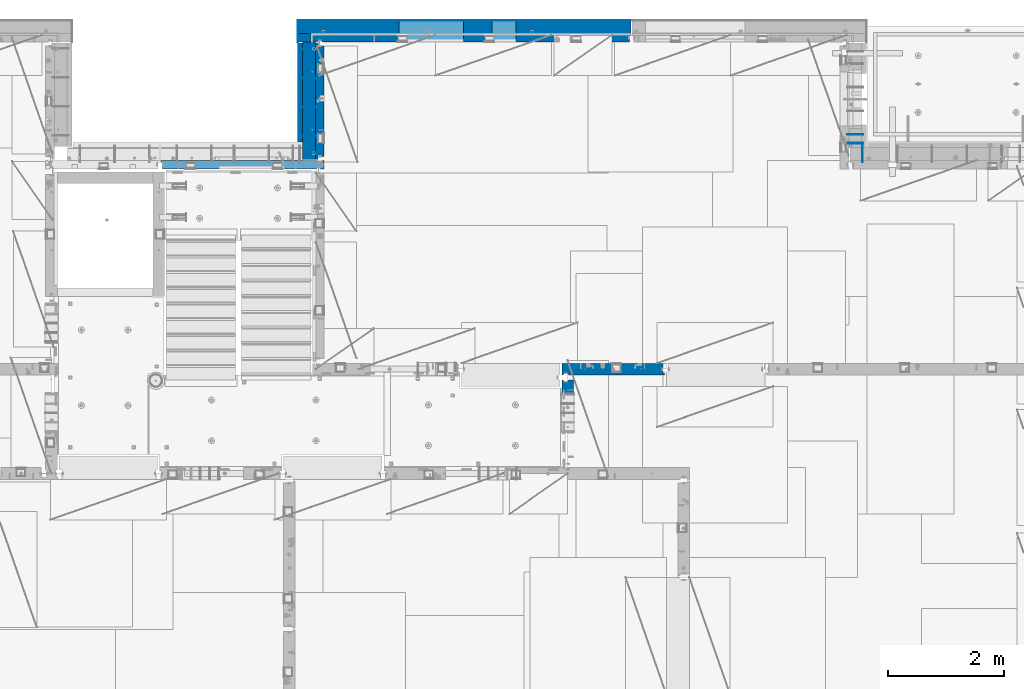
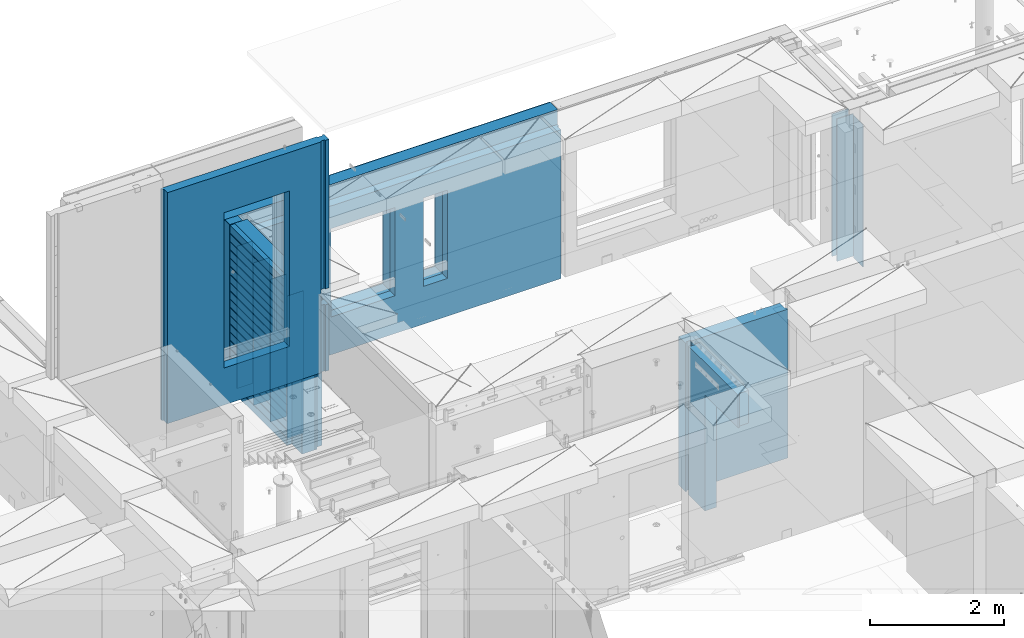
# One storey, part 241 of 352: 18 walls, 7 elements without a shape of their own.
"""IFC2X3 building model written with IfcOpenShell, lengths in millimetres."""

from ifc_helpers import new_model, si_unit, frame, origin_with_axes, place, context, subcontext, project, spatial, faceted_brep, material, type_object, element, aggregate, save


model = new_model("IFC2X3")

# Units and contexts
model_context = context("Model", 3, precision=1e-05, world=origin_with_axes())
body_context = subcontext(model_context, "Body", "Model", "MODEL_VIEW")
ifc_project = project(units=[si_unit("LENGTHUNIT", "METRE", prefix="MILLI"), si_unit("AREAUNIT", "SQUARE_METRE"), si_unit("VOLUMEUNIT", "CUBIC_METRE"), si_unit("MASSUNIT", "GRAM", prefix="KILO"), si_unit("TIMEUNIT", "SECOND"), si_unit("PLANEANGLEUNIT", "RADIAN"), si_unit("SOLIDANGLEUNIT", "STERADIAN"), si_unit("THERMODYNAMICTEMPERATUREUNIT", "DEGREE_CELSIUS"), si_unit("LUMINOUSINTENSITYUNIT", "LUMEN")], contexts=[model_context])

# Site, building, storey
site_placement = place(None, origin_with_axes())
site = spatial("IfcSite", under=ifc_project, at=site_placement, CompositionType="ELEMENT")
building_placement = place(site_placement, origin_with_axes())
building = spatial("IfcBuilding", under=site, at=building_placement, CompositionType="ELEMENT")
storey_placement = place(building_placement, origin_with_axes())
storey = spatial("IfcBuildingStorey", under=building, at=storey_placement, Name="6", CompositionType="ELEMENT", Elevation=0.0)

# Assembly, wall
assembly_1_placement = place(storey_placement, origin_with_axes())
assembly_1 = element("IfcElementAssembly", 1, at=assembly_1_placement, inside=storey, AssemblyPlace="NOTDEFINED", PredefinedType="REINFORCEMENT_UNIT")
ifc_material_1 = material(Name="Undefined")
wall_type_1 = type_object("IfcWallType", PredefinedType="NOTDEFINED")
wall_1_placement = place(assembly_1_placement, frame((31695.0, 20549.9951872276, 98115.0), z_axis=(0.0, 0.0, 1.0), x_axis=(0.0, 1.0, 0.0)))
wall_1 = element("IfcWall", 2, at=wall_1_placement, type_object=wall_type_1, material=ifc_material_1, Name="(PD)", context=body_context, shape_type="Brep", body=[
    faceted_brep([(0.0, 5.0, -1300.0), (0.0, 5.0, 1300.0), (280.0, 5.0, 1300.0), (280.0, 5.0, -1300.0), (0.0, -5.0, 1300.0), (280.0, -5.0, 1300.0), (0.0, -5.0, -1300.0), (280.0, -5.0, -1300.0)], [[[0, 1, 2, 3]], [[1, 4, 5, 2]], [[4, 6, 7, 5]], [[6, 0, 3, 7]], [[5, 7, 3, 2]], [[6, 4, 1, 0]]]),
])
aggregate(assembly_1, [wall_1])

# Assembly, walls
assembly_2_placement = place(storey_placement, origin_with_axes())
assembly_2 = element("IfcElementAssembly", 3, at=assembly_2_placement, inside=storey, AssemblyPlace="NOTDEFINED", PredefinedType="REINFORCEMENT_UNIT")
wall_2_placement = place(assembly_2_placement, frame((22290.0, 22495.0, 98110.0), z_axis=(0.0, 0.0, 1.0), x_axis=(-1.0, 3.00000001838171e-08, 0.0)))
wall_2 = element("IfcWall", 4, at=wall_2_placement, type_object=wall_type_1, material=ifc_material_1, Name="(PD)", context=body_context, shape_type="Brep", body=[
    faceted_brep([(0.0, 5.0, -1300.0), (0.0, 5.0, 1300.0), (280.0, 5.0, 1300.0), (280.0, 5.0, -1300.0), (0.0, -5.0, 1300.0), (280.0, -5.0, 1300.0), (0.0, -5.0, -1300.0), (280.0, -5.0, -1300.0)], [[[0, 1, 2, 3]], [[1, 4, 5, 2]], [[4, 6, 7, 5]], [[6, 0, 3, 7]], [[5, 7, 3, 2]], [[6, 4, 1, 0]]]),
])
wall_3_placement = place(assembly_2_placement, frame((22290.0, 21995.0, 98110.0), z_axis=(0.0, 0.0, 1.0), x_axis=(-1.0, 3.00000001838171e-08, 0.0)))
wall_3 = element("IfcWall", 5, at=wall_3_placement, type_object=wall_type_1, material=ifc_material_1, Name="(PD)", context=body_context, shape_type="Brep", body=[
    faceted_brep([(0.0, 5.0, -1300.0), (0.0, 5.0, 1300.0), (280.0, 5.0, 1300.0), (280.0, 5.0, -1300.0), (0.0, -5.0, 1300.0), (280.0, -5.0, 1300.0), (0.0, -5.0, -1300.0), (280.0, -5.0, -1300.0)], [[[0, 1, 2, 3]], [[1, 4, 5, 2]], [[4, 6, 7, 5]], [[6, 0, 3, 7]], [[5, 7, 3, 2]], [[6, 4, 1, 0]]]),
])
wall_4_placement = place(assembly_2_placement, frame((22290.0, 21495.0, 98110.0), z_axis=(0.0, 0.0, 1.0), x_axis=(-1.0, 3.00000001838171e-08, 0.0)))
wall_4 = element("IfcWall", 6, at=wall_4_placement, type_object=wall_type_1, material=ifc_material_1, Name="(PD)", context=body_context, shape_type="Brep", body=[
    faceted_brep([(0.0, 5.0, -1300.0), (0.0, 5.0, 1300.0), (280.0, 5.0, 1300.0), (280.0, 5.0, -1300.0), (0.0, -5.0, 1300.0), (280.0, -5.0, 1300.0), (0.0, -5.0, -1300.0), (280.0, -5.0, -1300.0)], [[[0, 1, 2, 3]], [[1, 4, 5, 2]], [[4, 6, 7, 5]], [[6, 0, 3, 7]], [[5, 7, 3, 2]], [[6, 4, 1, 0]]]),
])

assembly_3_placement = place(storey_placement, origin_with_axes())
assembly_3 = element("IfcElementAssembly", 7, at=assembly_3_placement, inside=storey, AssemblyPlace="NOTDEFINED", PredefinedType="REINFORCEMENT_UNIT")
wall_5_placement = place(assembly_3_placement, frame((31429.9951872276, 20875.0, 98115.0), z_axis=(0.0, 0.0, 1.0), x_axis=(1.0, 0.0, 0.0)))
wall_5 = element("IfcWall", 8, at=wall_5_placement, type_object=wall_type_1, material=ifc_material_1, Name="(PD)", context=body_context, shape_type="Brep", body=[
    faceted_brep([(0.0, 5.0, -1300.0), (0.0, 5.0, 1300.0), (280.0, 5.0, 1300.0), (280.0, 5.0, -1300.0), (0.0, -5.0, 1300.0), (280.0, -5.0, 1300.0), (0.0, -5.0, -1300.0), (280.0, -5.0, -1300.0)], [[[0, 1, 2, 3]], [[1, 4, 5, 2]], [[4, 6, 7, 5]], [[6, 0, 3, 7]], [[5, 7, 3, 2]], [[6, 4, 1, 0]]]),
])
wall_6_placement = place(assembly_3_placement, frame((31429.9951872276, 21025.0, 98115.0), z_axis=(0.0, 0.0, 1.0), x_axis=(1.0, 0.0, 0.0)))
wall_6 = element("IfcWall", 9, at=wall_6_placement, type_object=wall_type_1, material=ifc_material_1, Name="(PD)", context=body_context, shape_type="Brep", body=[
    faceted_brep([(0.0, 5.0, -1300.0), (0.0, 5.0, 1300.0), (280.0, 5.0, 1300.0), (280.0, 5.0, -1300.0), (0.0, -5.0, 1300.0), (280.0, -5.0, 1300.0), (0.0, -5.0, -1300.0), (280.0, -5.0, -1300.0)], [[[0, 1, 2, 3]], [[1, 4, 5, 2]], [[4, 6, 7, 5]], [[6, 0, 3, 7]], [[5, 7, 3, 2]], [[6, 4, 1, 0]]]),
])
aggregate(assembly_3, [wall_5, wall_6])

# Wall
wall_7_placement = place(assembly_2_placement, frame((22290.0, 20995.0, 98110.0), z_axis=(0.0, 0.0, 1.0), x_axis=(-1.0, 3.00000001838171e-08, 0.0)))
wall_7 = element("IfcWall", 10, at=wall_7_placement, type_object=wall_type_1, material=ifc_material_1, Name="(PD)", context=body_context, shape_type="Brep", body=[
    faceted_brep([(0.0, 5.0, -1300.0), (0.0, 5.0, 1300.0), (280.0, 5.0, 1300.0), (280.0, 5.0, -1300.0), (0.0, -5.0, 1300.0), (280.0, -5.0, 1300.0), (0.0, -5.0, -1300.0), (280.0, -5.0, -1300.0)], [[[0, 1, 2, 3]], [[1, 4, 5, 2]], [[4, 6, 7, 5]], [[6, 0, 3, 7]], [[5, 7, 3, 2]], [[6, 4, 1, 0]]]),
])

# Assembly, wall
assembly_4_placement = place(storey_placement, origin_with_axes())
assembly_4 = element("IfcElementAssembly", 11, at=assembly_4_placement, inside=storey, AssemblyPlace="NOTDEFINED", PredefinedType="REINFORCEMENT_UNIT")
ifc_material_2 = material(Name="CONCRETE/C25/30")
wall_type_2 = type_object("IfcWallType", PredefinedType="NOTDEFINED")
wall_8_placement = place(assembly_4_placement, frame((26510.0014364077, 16980.0, 98112.5), z_axis=(0.0, 0.0, 1.0), x_axis=(1.0, 0.0, 0.0)))
wall_8 = element("IfcWall", 12, at=wall_8_placement, type_object=wall_type_2, material=ifc_material_2, context=body_context, shape_type="Brep", body=[
    faceted_brep([(1739.99847412109, 100.0, 1357.5), (1739.99847412109, -57.0, 1357.5), (1739.99847412109, -57.0, -1357.5), (1739.99847412109, 100.0, -1357.5), (1769.99847412109, -70.0, 1357.5), (1769.99847412109, -70.0, -1357.5), (0.0, -100.0, -1357.5), (0.0, -100.0, 1357.5), (0.0, 100.0, 1357.5), (0.0, 100.0, -1357.5), (29.998563592264, -100.0, -1357.5), (29.998563592264, -100.0, 1357.5), (29.998563592264, -80.0008544921875, -1357.5), (29.998563592264, -80.0008544921875, 1357.5), (109.998563592264, -80.0008544921875, -1357.5), (109.998563592264, -80.0008544921875, 1357.5), (109.998563592264, -100.0, -1357.5), (109.998563592264, -100.0, 1357.5), (1769.99847412109, -100.0, -1357.5), (1769.99847412109, -100.0, 1357.5)], [[[0, 1, 2, 3]], [[4, 5, 2, 1]], [[6, 7, 8, 9]], [[7, 6, 10, 11]], [[11, 10, 12, 13]], [[13, 12, 14, 15]], [[15, 14, 16, 17]], [[18, 19, 17, 16]], [[0, 8, 7, 11, 13, 15, 17, 19, 4, 1]], [[9, 8, 0, 3]], [[18, 16, 14, 12, 10, 6, 9, 3, 2, 5]], [[19, 18, 5, 4]]]),
])
aggregate(assembly_4, [wall_8])

assembly_5_placement = place(storey_placement, origin_with_axes())
assembly_5 = element("IfcElementAssembly", 13, at=assembly_5_placement, inside=storey, AssemblyPlace="NOTDEFINED", PredefinedType="REINFORCEMENT_UNIT")
wall_9_placement = place(assembly_5_placement, frame((26609.9991475894, 15280.0004107749, 98112.5), z_axis=(0.0, 0.0, 1.0), x_axis=(0.0, 1.0, 0.0)))
wall_9 = element("IfcWall", 14, at=wall_9_placement, type_object=wall_type_2, material=ifc_material_2, context=body_context, shape_type="Brep", body=[
    faceted_brep([(1509.99949975397, 70.0, 1357.5), (1489.99949975397, 70.0, 1357.5), (1489.99949975397, 70.0, -1357.5), (1509.99949975397, 70.0, -1357.5), (1489.99949975397, -10.0, 1357.5), (1489.99949975397, -10.0, -1357.5), (1509.99949975397, -10.0, 1357.5), (1509.99949975397, -10.0, -1357.5), (29.9995892251427, 70.0, 1357.5), (29.9995892251427, 70.0, 762.5), (59.9995892251427, 57.0, 762.5), (59.9995892251427, 57.0, 1357.5), (29.9995892251427, 100.0, 1357.5), (29.9995892251427, 100.0, 762.5), (1509.99949975397, 100.0, 1357.5), (1509.99949975397, 100.0, -1357.5), (1019.99979369292, 100.0, -1357.5), (1019.99979369292, 100.0, 762.5), (1019.99979369292, -100.0, 762.5), (1019.99979369292, -100.0, -1357.5), (59.9995892251427, -100.0, 762.5), (59.9995892251427, -100.0, 1357.5), (1509.99949975397, -100.0, -1357.5), (1509.99949975397, -100.0, 1357.5)], [[[0, 1, 2, 3]], [[4, 5, 2, 1]], [[6, 7, 5, 4]], [[8, 9, 10, 11]], [[12, 13, 9, 8]], [[12, 14, 15, 16, 17, 13]], [[18, 17, 16, 19]], [[9, 13, 17, 18, 20, 10]], [[21, 11, 10, 20]], [[18, 19, 22, 23, 21, 20]], [[1, 0, 14, 12, 8, 11, 21, 23, 6, 4]], [[15, 14, 0, 3]], [[22, 19, 16, 15, 3, 2, 5, 7]], [[23, 22, 7, 6]]]),
])
aggregate(assembly_5, [wall_9])

# Wall
ifc_material_3 = material(Name="COS5gt")
wall_type_3 = type_object("IfcWallType", PredefinedType="NOTDEFINED")
wall_10_placement = place(assembly_2_placement, frame((22150.0, 20595.0, 98247.5), z_axis=(0.0, 0.0, 1.0), x_axis=(0.0, 1.0, 0.0)))
wall_10 = element("IfcWall", 15, at=wall_10_placement, type_object=wall_type_3, material=ifc_material_3, context=body_context, shape_type="Brep", body=[
    faceted_brep([(0.0, 110.0, -1492.5), (0.0, 110.0, 1492.5), (2025.0, 110.0, 1492.5), (2025.0, 110.0, -1492.5), (0.0, -110.0, 1492.5), (2025.0, -110.0, 1492.5), (0.0, -110.0, -1492.5), (2025.0, -110.0, -1492.5)], [[[0, 1, 2, 3]], [[1, 4, 5, 2]], [[4, 6, 7, 5]], [[6, 0, 3, 7]], [[5, 7, 3, 2]], [[6, 4, 1, 0]]]),
])

# Assembly, walls
assembly_6_placement = place(storey_placement, origin_with_axes())
assembly_6 = element("IfcElementAssembly", 16, at=assembly_6_placement, inside=storey, AssemblyPlace="NOTDEFINED", PredefinedType="REINFORCEMENT_UNIT")
ifc_material_4 = material()
wall_11_placement = place(assembly_6_placement, frame((22075.0, 22620.0, 98247.5), z_axis=(0.0, 0.0, 1.0), x_axis=(0.0, 1.0, 0.0)))
wall_11 = element("IfcWall", 17, at=wall_11_placement, type_object=wall_type_3, material=ifc_material_4, context=body_context, shape_type="Brep", body=[
    faceted_brep([(0.0, 110.0, -1492.5), (0.0, 110.0, 1492.5), (150.0, 110.0, 1492.5), (150.0, 110.0, -1492.5), (0.0, -110.0, 1492.5), (150.0, -110.0, 1492.5), (0.0, -110.0, -1492.5), (150.0, -110.0, -1492.5)], [[[0, 1, 2, 3]], [[1, 4, 5, 2]], [[4, 6, 7, 5]], [[6, 0, 3, 7]], [[5, 7, 3, 2]], [[6, 4, 1, 0]]]),
])
wall_12_placement = place(assembly_6_placement, frame((22260.0, 22880.0, 98247.5), z_axis=(0.0, 0.0, 1.0), x_axis=(1.0, 0.0, 0.0)))
wall_12 = element("IfcWall", 18, at=wall_12_placement, type_object=wall_type_3, material=ifc_material_4, context=body_context, shape_type="Brep", body=[
    faceted_brep([(-295.0, 110.0, 1492.5), (-295.0, -110.0, 1492.5), (5445.0, -110.0, 1492.5), (5445.0, 110.0, 1492.5), (-295.0, -110.0, -1492.5), (-295.0, 110.0, -1492.5), (5445.0, 110.0, -1492.5), (5445.0, -110.0, -1492.5), (3044.99635379813, 110.0, -802.5), (3454.99635379813, 110.0, -802.5), (3454.99635379813, 110.0, 807.5), (3044.99635379813, 110.0, 807.5), (1444.99910133321, 110.0, -802.5), (2554.99910133321, 110.0, -802.5), (2554.99910133321, 110.0, 807.5), (1444.99910133321, 110.0, 807.5), (1444.99910133321, -110.0, -802.5), (2554.99910133321, -110.0, -802.5), (1444.99910133321, -110.0, 807.5), (2554.99910133321, -110.0, 807.5), (3044.99635379813, -110.0, -802.5), (3044.99635379813, -110.0, 807.5), (3454.99635379813, -110.0, 807.5), (3454.99635379813, -110.0, -802.5)], [[[0, 1, 2, 3]], [[4, 1, 0, 5]], [[4, 5, 6, 7]], [[2, 7, 6, 3]], [[5, 0, 3, 6], [8, 9, 10, 11], [12, 13, 14, 15]], [[12, 16, 17, 13]], [[15, 18, 16, 12]], [[14, 19, 18, 15]], [[13, 17, 19, 14]], [[1, 4, 7, 2], [20, 21, 22, 23], [16, 18, 19, 17]], [[10, 22, 21, 11]], [[9, 23, 22, 10]], [[8, 20, 23, 9]], [[11, 21, 20, 8]]]),
])

# Wall
ifc_material_5 = material(Name="CONCRETE/C30/37")
wall_type_4 = type_object("IfcWallType", PredefinedType="NOTDEFINED")
wall_13_placement = place(assembly_2_placement, frame((21997.5, 20900.0, 98247.5), z_axis=(0.0, 0.0, 1.0), x_axis=(0.0, 1.0, 0.0)))
wall_13 = element("IfcWall", 19, at=wall_13_placement, type_object=wall_type_4, material=ifc_material_5, context=body_context, shape_type="Brep", body=[
    faceted_brep([(1705.0, 42.5, -1357.0), (0.0, 42.5, -1357.00000005524), (0.0, 32.4999992507037, -1355.00000000074), (1705.0, 32.5, -1355.0), (1705.0, 32.5, -1345.0), (0.0, 32.4999991127006, -1344.99999959956), (0.0, 42.5, -1343.00000011075), (1705.0, 42.5, -1343.0), (0.0, -42.5, -1492.5), (0.0, 42.5, -1492.5), (1705.0, 42.5, -1492.5), (1705.0, -42.5, -1492.5), (0.0, -42.5, 1492.5), (1705.0, -42.5, 1492.5), (0.0, 42.5, 1492.5), (1705.0, 42.5, 1492.5), (1705.0, 42.5, 1357.0), (0.0, 42.5, 1356.99999988925), (1705.0, 32.5, 1355.0), (-3.63797880709171e-12, 32.4999991127006, 1355.00000040044), (1705.0, 32.5, 1345.0), (-3.63797880709171e-12, 32.4999992507037, 1344.99999999926), (1705.0, 42.5, 1343.0), (0.0, 42.5, 1342.99999994476), (1705.0, 42.5, 1207.0), (0.0, 42.5, 1206.99999988925), (1705.0, 32.5, 1205.0), (0.0, 32.4999991127006, 1205.00000040044), (1705.0, 32.5, 1195.0), (0.0, 32.4999992507037, 1194.99999999926), (1705.0, 42.5, 1193.0), (0.0, 42.5, 1192.99999994476), (1705.0, 42.5, 1057.0), (0.0, 42.5, 1056.99999988925), (1705.0, 32.5, 1055.0), (0.0, 32.4999991127006, 1055.00000040044), (1705.0, 32.5, 1045.0), (0.0, 32.4999992507037, 1044.99999999926), (1705.0, 42.5, 1043.0), (0.0, 42.5, 1042.99999994476), (1705.0, 42.5, 907.0), (0.0, 42.5, 906.999999889245), (1705.0, 32.5, 905.0), (0.0, 32.4999991127006, 905.00000040044), (1705.0, 32.5, 895.0), (0.0, 32.4999992507037, 894.999999999258), (1705.0, 42.5, 893.0), (0.0, 42.5, 892.999999944761), (1705.0, 42.5, 757.0), (0.0, 42.5, 756.999999889245), (1705.0, 32.5, 755.0), (0.0, 32.4999991127006, 755.00000040044), (1705.0, 32.5, 745.0), (0.0, 32.4999992507037, 744.999999999258), (1705.0, 42.5, 743.0), (0.0, 42.5, 742.999999944761), (1705.0, 42.5, 607.0), (0.0, 42.5, 606.999999889245), (1705.0, 32.5, 605.0), (3.63797880709171e-12, 32.4999991127006, 605.00000040044), (1705.0, 32.5, 595.0), (3.63797880709171e-12, 32.4999992507037, 594.999999999258), (1705.0, 42.5, 593.0), (0.0, 42.5, 592.999999944761), (1705.0, 42.5, 457.0), (0.0, 42.5, 456.999999889245), (1705.0, 32.5, 455.0), (0.0, 32.4999991127006, 455.00000040044), (1705.0, 32.5, 445.0), (0.0, 32.4999992507037, 444.999999999258), (1705.0, 42.5, 443.0), (0.0, 42.5, 442.999999944761), (1705.0, 42.5, 307.0), (0.0, 42.5, 306.999999889245), (1705.0, 32.5, 305.0), (-3.63797880709171e-12, 32.4999991127006, 305.00000040044), (1705.0, 32.5, 295.0), (-3.63797880709171e-12, 32.4999992507037, 294.999999999258), (1705.0, 42.5, 293.0), (0.0, 42.5, 292.999999944761), (1705.0, 42.5, 157.0), (0.0, 42.5, 156.999999889245), (1705.0, 32.5, 155.0), (-3.63797880709171e-12, 32.4999991127006, 155.00000040044), (1705.0, 32.5, 145.0), (-3.63797880709171e-12, 32.4999992507037, 144.999999999258), (1705.0, 42.5, 143.0), (0.0, 42.5, 142.999999944761), (1705.0, 42.5, 7.0), (0.0, 42.5, 6.99999988924537), (1705.0, 32.5, 5.0), (0.0, 32.4999991127006, 5.0000004004396), (1705.0, 32.5, -5.0), (0.0, 32.4999992507037, -5.00000000074215), (1705.0, 42.5, -7.0), (0.0, 42.5, -7.00000005523907), (1705.0, 42.5, -143.0), (0.0, 42.5, -143.000000110755), (1705.0, 32.5, -145.0), (3.63797880709171e-12, 32.4999991127006, -144.99999959956), (1705.0, 32.5, -155.0), (3.63797880709171e-12, 32.4999992507037, -155.000000000742), (1705.0, 42.5, -157.0), (0.0, 42.5, -157.000000055239), (1705.0, 42.5, -293.0), (0.0, 42.5, -293.000000110755), (1705.0, 32.5, -295.0), (0.0, 32.4999991127006, -294.99999959956), (1705.0, 32.5, -305.0), (0.0, 32.4999992507037, -305.000000000742), (1705.0, 42.5, -307.0), (0.0, 42.5, -307.000000055239), (1705.0, 42.5, -443.0), (0.0, 42.5, -443.000000110755), (1705.0, 32.5, -445.0), (0.0, 32.4999991127006, -444.99999959956), (1705.0, 32.5, -455.0), (0.0, 32.4999992507037, -455.000000000742), (1705.0, 42.5, -457.0), (0.0, 42.5, -457.000000055239), (1705.0, 42.5, -593.0), (0.0, 42.5, -593.000000110755), (1705.0, 32.5, -595.0), (3.63797880709171e-12, 32.4999991127006, -594.99999959956), (1705.0, 32.5, -605.0), (3.63797880709171e-12, 32.4999992507037, -605.000000000742), (1705.0, 42.5, -607.0), (0.0, 42.5, -607.000000055239), (1705.0, 42.5, -743.0), (0.0, 42.5, -743.000000110755), (1705.0, 32.5, -745.0), (0.0, 32.4999991127006, -744.99999959956), (1705.0, 32.5, -755.0), (0.0, 32.4999992507037, -755.000000000742), (1705.0, 42.5, -757.0), (0.0, 42.5, -757.000000055239), (1705.0, 42.5, -893.0), (0.0, 42.5, -893.000000110755), (1705.0, 32.5, -895.0), (0.0, 32.4999991127006, -894.99999959956), (1705.0, 32.5, -905.0), (0.0, 32.4999992507037, -905.000000000742), (1705.0, 42.5, -907.0), (0.0, 42.5, -907.000000055239), (1705.0, 42.5, -1043.0), (0.0, 42.5, -1043.00000011075), (1705.0, 32.5, -1045.0), (0.0, 32.4999991127006, -1044.99999959956), (1705.0, 32.5, -1055.0), (0.0, 32.4999992507037, -1055.00000000074), (1705.0, 42.5, -1057.0), (0.0, 42.5, -1057.00000005524), (1705.0, 42.5, -1193.0), (0.0, 42.5, -1193.00000011075), (1705.0, 32.5, -1195.0), (0.0, 32.4999991127006, -1194.99999959956), (1705.0, 32.5, -1205.0), (0.0, 32.4999992507037, -1205.00000000074), (1705.0, 42.5, -1207.0), (0.0, 42.5, -1207.00000005524)], [[[0, 1, 2, 3]], [[4, 5, 6, 7]], [[3, 2, 5, 4]], [[8, 9, 10, 11]], [[12, 8, 11, 13]], [[14, 12, 13, 15]], [[14, 15, 16, 17]], [[18, 19, 17, 16]], [[20, 21, 19, 18]], [[22, 23, 21, 20]], [[24, 25, 23, 22]], [[26, 27, 25, 24]], [[28, 29, 27, 26]], [[30, 31, 29, 28]], [[32, 33, 31, 30]], [[34, 35, 33, 32]], [[36, 37, 35, 34]], [[38, 39, 37, 36]], [[40, 41, 39, 38]], [[42, 43, 41, 40]], [[44, 45, 43, 42]], [[46, 47, 45, 44]], [[48, 49, 47, 46]], [[50, 51, 49, 48]], [[52, 53, 51, 50]], [[54, 55, 53, 52]], [[56, 57, 55, 54]], [[58, 59, 57, 56]], [[60, 61, 59, 58]], [[62, 63, 61, 60]], [[64, 65, 63, 62]], [[66, 67, 65, 64]], [[68, 69, 67, 66]], [[70, 71, 69, 68]], [[72, 73, 71, 70]], [[74, 75, 73, 72]], [[76, 77, 75, 74]], [[78, 79, 77, 76]], [[80, 81, 79, 78]], [[82, 83, 81, 80]], [[84, 85, 83, 82]], [[86, 87, 85, 84]], [[88, 89, 87, 86]], [[90, 91, 89, 88]], [[92, 93, 91, 90]], [[94, 95, 93, 92]], [[96, 97, 95, 94]], [[98, 99, 97, 96]], [[100, 101, 99, 98]], [[102, 103, 101, 100]], [[104, 105, 103, 102]], [[106, 107, 105, 104]], [[108, 109, 107, 106]], [[110, 111, 109, 108]], [[112, 113, 111, 110]], [[114, 115, 113, 112]], [[116, 117, 115, 114]], [[118, 119, 117, 116]], [[120, 121, 119, 118]], [[122, 123, 121, 120]], [[124, 125, 123, 122]], [[126, 127, 125, 124]], [[128, 129, 127, 126]], [[130, 131, 129, 128]], [[132, 133, 131, 130]], [[134, 135, 133, 132]], [[136, 137, 135, 134]], [[138, 139, 137, 136]], [[140, 141, 139, 138]], [[142, 143, 141, 140]], [[144, 145, 143, 142]], [[146, 147, 145, 144]], [[148, 149, 147, 146]], [[150, 151, 149, 148]], [[152, 153, 151, 150]], [[154, 155, 153, 152]], [[156, 157, 155, 154]], [[158, 159, 157, 156]], [[7, 6, 159, 158]], [[21, 23, 25, 27, 29, 31, 33, 35, 37, 39, 41, 43, 45, 47, 49, 51, 53, 55, 57, 59, 61, 63, 65, 67, 69, 71, 73, 75, 77, 79, 81, 83, 85, 87, 89, 91, 93, 95, 97, 99, 101, 103, 105, 107, 109, 111, 113, 115, 117, 119, 121, 123, 125, 127, 129, 131, 133, 135, 137, 139, 141, 143, 145, 147, 149, 151, 153, 155, 157, 159, 6, 5, 2, 1, 9, 8, 12, 14, 17, 19]], [[10, 9, 1, 0]], [[15, 13, 11, 10, 0, 3, 4, 7, 158, 156, 154, 152, 150, 148, 146, 144, 142, 140, 138, 136, 134, 132, 130, 128, 126, 124, 122, 120, 118, 116, 114, 112, 110, 108, 106, 104, 102, 100, 98, 96, 94, 92, 90, 88, 86, 84, 82, 80, 78, 76, 74, 72, 70, 68, 66, 64, 62, 60, 58, 56, 54, 52, 50, 48, 46, 44, 42, 40, 38, 36, 34, 32, 30, 28, 26, 24, 22, 20, 18, 16]]]),
])

wall_type_5 = type_object("IfcWallType", PredefinedType="NOTDEFINED")
wall_14_placement = place(assembly_6_placement, frame((22192.5, 22695.0, 98112.5), z_axis=(0.0, 0.0, 1.0), x_axis=(1.0, 0.0, 0.0)))
wall_14 = element("IfcWall", 20, at=wall_14_placement, type_object=wall_type_5, material=ifc_material_2, context=body_context, shape_type="Brep", body=[
    faceted_brep([(3112.49635379813, 75.0, 942.5), (3112.49635379813, -75.0000009061441, 942.5), (3112.49635379813, -75.0000002303786, -667.5), (3112.49635379813, 75.0, -667.5), (3522.49635379813, -75.0000001420558, -667.5), (3522.49635379813, 75.0, -667.5), (3522.49635379813, -75.0000008178213, 942.5), (3522.49635379813, 75.0, 942.5), (5482.5, -75.0, 1357.5), (5482.5, -75.0, -1357.5), (5482.5, 24.9999980926514, -1357.5), (5482.5, 24.9999980926514, 1357.5), (5512.5, 45.0, 1357.5), (5512.5, 75.0, 1357.5), (0.0, 75.0, 1357.5), (0.0, -75.0, 1357.5), (92.5, -75.0, 1357.5), (102.5, -55.0000022791319, 1357.5), (182.5, -55.0000022791319, 1357.5), (192.5, -75.0000022791319, 1357.5), (0.0, -75.0, -1357.5), (0.0, 75.0, -1357.5), (92.5, -75.0, -1357.5), (102.5, -55.0000022791319, -1357.5), (182.5, -55.0000022791319, -1357.5), (192.5, -75.0, -1357.5), (5512.5, 75.0, -1357.5), (5512.5, 45.0, -1357.5), (1512.49910133321, 75.0, -667.5), (2622.49910133321, 75.0, -667.5), (2622.49910133321, 75.0, 942.5), (1512.49910133321, 75.0, 942.5), (1512.49910133321, -75.000000575048, -667.5), (2622.49910133321, -75.000000335931, -667.5), (1512.49910133321, -75.0000012508135, 942.5), (2622.49910133321, -75.0000010116964, 942.5)], [[[0, 1, 2, 3]], [[3, 2, 4, 5]], [[5, 4, 6, 7]], [[7, 6, 1, 0]], [[8, 9, 10, 11]], [[8, 11, 12, 13, 14, 15, 16, 17, 18, 19]], [[20, 15, 14, 21]], [[15, 20, 22, 16]], [[16, 22, 23, 17]], [[17, 23, 24, 18]], [[19, 18, 24, 25]], [[23, 22, 20, 21, 26, 27, 10, 9, 25, 24]], [[12, 11, 10, 27]], [[26, 13, 12, 27]], [[21, 14, 13, 26], [3, 5, 7, 0], [28, 29, 30, 31]], [[28, 32, 33, 29]], [[31, 34, 32, 28]], [[30, 35, 34, 31]], [[29, 33, 35, 30]], [[9, 8, 19, 25], [2, 1, 6, 4], [32, 34, 35, 33]]]),
])

wall_15_placement = place(assembly_2_placement, frame((22335.0, 20595.0, 98112.5), z_axis=(0.0, 0.0, 1.0), x_axis=(0.0, 1.0, 0.0)))
wall_15 = element("IfcWall", 21, at=wall_15_placement, type_object=wall_type_5, material=ifc_material_2, context=body_context, shape_type="Brep", body=[
    faceted_brep([(0.0, 40.0, 1357.5), (0.0, 40.0, -1357.5), (50.0, 27.0, -1357.5), (50.0, 27.0, 1357.5), (50.0, -75.0, 1357.5), (50.0, -75.0, -1357.5), (0.0, 75.0, -1357.5), (0.0, 75.0, 1357.5), (2009.99999772087, 75.0, 1357.5), (2009.99999772087, 75.0, -1357.5), (2009.99999772087, 40.0, 1357.5), (2009.99999772087, 40.0, -1357.5), (1959.99999772087, 27.0, 1357.5), (1959.99999772087, 27.0, -1357.5), (1959.99999772087, -75.0, 1357.5), (1959.99999772087, -75.0, -1357.5)], [[[0, 1, 2, 3]], [[4, 3, 2, 5]], [[6, 7, 8, 9]], [[9, 8, 10, 11]], [[12, 13, 11, 10]], [[14, 15, 13, 12]], [[15, 14, 4, 5]], [[1, 6, 9, 11, 13, 15, 5, 2]], [[7, 6, 1, 0]], [[14, 12, 10, 8, 7, 0, 3, 4]]]),
])

aggregate(assembly_2, [wall_10, wall_2, wall_3, wall_4, wall_7, wall_13, wall_15])

wall_type_6 = type_object("IfcWallType", PredefinedType="NOTDEFINED")
wall_16_placement = place(assembly_6_placement, frame((21960.0001313636, 22620.0, 98247.5), z_axis=(0.0, 0.0, 1.0), x_axis=(0.0, 1.0, 0.0)))
wall_16 = element("IfcWall", 22, at=wall_16_placement, type_object=wall_type_6, material=ifc_material_5, context=body_context, shape_type="Brep", body=[
    faceted_brep([(0.0, 5.0, -1492.5), (0.0, 5.0, 1492.5), (370.0, 5.0, 1492.5), (370.0, 5.0, -1492.5), (0.0, -5.0, 1492.5), (370.0, -5.0, 1492.5), (0.0, -5.0, -1492.5), (370.0, -5.0, -1492.5)], [[[0, 1, 2, 3]], [[1, 4, 5, 2]], [[4, 6, 7, 5]], [[6, 0, 3, 7]], [[5, 7, 3, 2]], [[6, 4, 1, 0]]]),
])

wall_17_placement = place(assembly_6_placement, frame((22260.0, 22995.0, 98247.5), z_axis=(0.0, 0.0, 1.0), x_axis=(1.0, 0.0, 0.0)))
wall_17 = element("IfcWall", 23, at=wall_17_placement, type_object=wall_type_6, material=ifc_material_5, context=body_context, shape_type="Brep", body=[
    faceted_brep([(-305.0, 5.0, 1492.5), (-305.0, -5.0, 1492.5), (5445.0, -5.0, 1492.5), (5445.0, 5.0, 1492.5), (-305.0, -5.0, -1492.5), (-305.0, 5.0, -1492.5), (5445.0, 5.0, -1492.5), (5445.0, -5.0, -1492.5), (3044.99635379813, 5.0, -802.5), (3454.99635379813, 5.0, -802.5), (3454.99635379813, 5.0, 807.5), (3044.99635379813, 5.0, 807.5), (1444.99910133321, 5.0, -802.5), (2554.99910133321, 5.0, -802.5), (2554.99910133321, 5.0, 807.5), (1444.99910133321, 5.0, 807.5), (1444.99910133321, -5.0, -802.5), (2554.99910133321, -5.0, -802.5), (1444.99910133321, -5.0, 807.5), (2554.99910133321, -5.0, 807.5), (3044.99635379813, -5.0, -802.5), (3044.99635379813, -5.0, 807.5), (3454.99635379813, -5.0, 807.5), (3454.99635379813, -5.0, -802.5)], [[[0, 1, 2, 3]], [[4, 1, 0, 5]], [[4, 5, 6, 7]], [[2, 7, 6, 3]], [[5, 0, 3, 6], [8, 9, 10, 11], [12, 13, 14, 15]], [[12, 16, 17, 13]], [[15, 18, 16, 12]], [[14, 19, 18, 15]], [[13, 17, 19, 14]], [[1, 4, 7, 2], [20, 21, 22, 23], [16, 18, 19, 17]], [[10, 22, 21, 11]], [[9, 23, 22, 10]], [[8, 20, 23, 9]], [[11, 21, 20, 8]]]),
])

aggregate(assembly_6, [wall_16, wall_11, wall_12, wall_17, wall_14])

# Assembly, wall
assembly_7_placement = place(storey_placement, origin_with_axes())
assembly_7 = element("IfcElementAssembly", 24, at=assembly_7_placement, inside=storey, AssemblyPlace="NOTDEFINED", PredefinedType="REINFORCEMENT_UNIT")
wall_type_7 = type_object("IfcWallType", PredefinedType="NOTDEFINED")
wall_18_placement = place(assembly_7_placement, frame((19590.0, 20505.0, 100362.5), z_axis=(0.0, 0.0, 1.0), x_axis=(1.0, 0.0, 0.0)))
wall_18 = element("IfcWall", 25, at=wall_18_placement, type_object=wall_type_7, material=ifc_material_2, context=body_context, shape_type="Brep", body=[
    faceted_brep([(2820.0, 75.0, -892.500000000029), (2794.99999933574, 75.000000012893, -892.500000000029), (2785.0000011171, 55.0000001731059, -892.500000000029), (2704.99999994252, 55.0000001373228, -892.500000000029), (2695.0, 75.0, -892.500000000029), (2695.00000000002, -54.9999998677631, -892.5), (2746.9999998731, -54.9999987450828, -892.500000000015), (2760.00000278436, -75.0000006569353, -892.5), (2820.0, -75.0, -892.5), (2695.0, 75.0, -602.5), (2695.00000000002, -54.9999998677631, -602.5), (2820.00000000002, 74.9999999999709, -602.5), (2820.0, -75.0, -602.5), (2760.00000278436, -75.0000008137358, -602.5), (2746.9999998731, -54.9999987450828, -602.5), (2704.99999994252, 55.0000001373228, -602.5), (2785.0000011171, 55.0000001731059, -602.5), (2794.99999933574, 75.0000000159707, -602.5), (2679.99999584191, -75.0, 2107.5), (2679.99999584191, -75.0, -2107.5), (2692.99999996855, -54.9999999109423, -2107.5), (2692.99999996855, -54.9999999109423, 2107.5), (2794.99999933574, 75.0000000447253, 2107.5), (2820.0, 75.0, 2107.5), (2785.0000011171, 55.0000001731059, 2107.5), (2704.99999994252, 55.0000001373228, 2107.5), (2695.0, 75.0, 2107.5), (2746.9999998731, -54.9999987450828, 2107.5), (2760.00000278436, -75.0000022790009, 2107.5), (2820.0, -75.0, 2107.5), (0.0, 75.0, 2107.5), (0.0, 45.0, 2107.5), (29.9999989349526, 25.0000007100352, 2107.5), (30.0000010509684, -75.0, 2107.5), (0.0, 75.0, -2107.5), (0.0, 45.0, -2107.5), (29.9999989349526, 25.0000007100352, -2107.5), (2695.0, 75.0, -2107.5), (2704.99999994252, 55.0000001373228, -2107.5), (2785.0000011171, 55.0000001731059, -2107.5), (2794.99999933574, 75.0, -2107.5), (2820.0, 75.0, -2107.5), (2820.0, -75.0, -2107.5), (2760.00000278436, -75.0, -2107.5), (2746.9999998731, -54.9999987450828, -2107.5), (30.0000010509684, -75.0, -2107.5), (1004.99840497971, -75.0000022790009, -1432.5), (1004.99840497971, -75.0000022790009, 1402.5), (2134.99840497971, -75.0000022790009, 1402.5), (2134.99840497971, -75.0000022790009, -1432.5), (1009.05245909535, 75.0, 1398.44594588435), (1009.05245909535, 75.0, -1428.44594588435), (2130.94435086406, 75.0, -1428.44594588435), (2130.94435086406, 75.0, 1398.44594588435)], [[[0, 1, 2, 3, 4, 5, 6, 7, 8]], [[9, 10, 5, 4]], [[11, 12, 13, 14, 10, 9, 15, 16, 17]], [[18, 19, 20, 21]], [[22, 23, 11, 17]], [[24, 22, 17, 16]], [[25, 24, 16, 15]], [[26, 25, 15, 9]], [[18, 21, 27, 28, 29, 23, 22, 24, 25, 26, 30, 31, 32, 33]], [[30, 34, 35, 31]], [[31, 35, 36, 32]], [[34, 37, 38, 39, 40, 41, 42, 43, 44, 20, 19, 45, 36, 35]], [[32, 36, 45, 33]], [[19, 18, 33, 45], [46, 47, 48, 49]], [[50, 47, 46, 51]], [[49, 52, 51, 46]], [[48, 53, 52, 49]], [[47, 50, 53, 48]], [[37, 34, 30, 26, 9, 4], [51, 52, 53, 50]], [[38, 37, 4, 3]], [[39, 38, 3, 2]], [[40, 39, 2, 1]], [[41, 40, 1, 0]], [[42, 41, 0, 8]], [[43, 42, 8, 7]], [[44, 43, 7, 6]], [[27, 21, 20, 44, 6, 5, 10, 14]], [[28, 27, 14, 13]], [[29, 28, 13, 12]], [[23, 29, 12, 11]]]),
])
aggregate(assembly_7, [wall_18])

save(model, "model.ifc")
